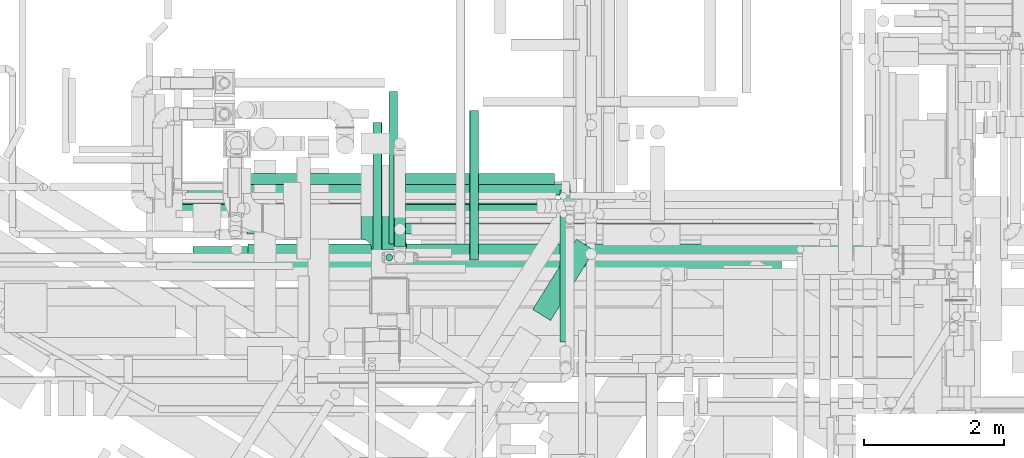
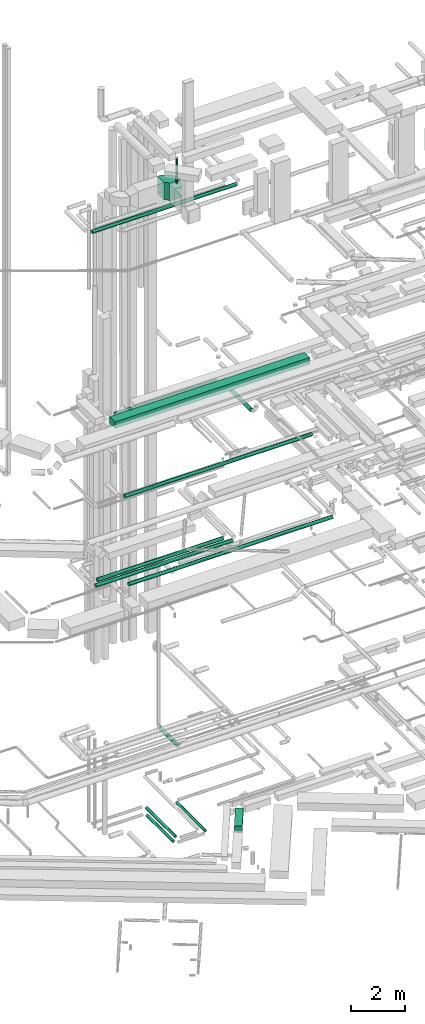
# One storey, part 27 of 337: 14 flow segments, 1 flow fitting.
"""IFC2X3 building model written with IfcOpenShell, lengths in millimetres."""

from ifc_helpers import new_model, entity, si_unit, converted_unit, derived_unit, direction, frame, frame_2d, origin, origin_2d_with_axis, place, context, subcontext, project, spatial, polyline, circle_curve, parameter, trimmed, segment, composite_curve, rectangle, circle, outline, extrude, source, transform, mapped, material, type_object, type_shapes, element, save


model = new_model("IFC2X3")

# Units and contexts
model_context = context("Model", 3, precision=0.01, world=origin(), true_north=direction((6.12303176911189e-17, 1.0)))
body_context = subcontext(model_context, "Body", "Model", "MODEL_VIEW")
ifc_project = project(units=[si_unit("LENGTHUNIT", "METRE", prefix="MILLI"), si_unit("AREAUNIT", "SQUARE_METRE"), si_unit("VOLUMEUNIT", "CUBIC_METRE"), converted_unit("PLANEANGLEUNIT", "DEGREE", entity("IfcRatioMeasure", 0.0174532925199433), si_unit("PLANEANGLEUNIT", "RADIAN"), dimensions=[0, 0, 0, 0, 0, 0, 0]), si_unit("MASSUNIT", "GRAM", prefix="KILO"), derived_unit("MASSDENSITYUNIT", [(si_unit("MASSUNIT", "GRAM", prefix="KILO"), 1), (si_unit("LENGTHUNIT", "METRE"), -3)]), derived_unit("MOMENTOFINERTIAUNIT", [(si_unit("LENGTHUNIT", "METRE"), 4)]), si_unit("TIMEUNIT", "SECOND"), si_unit("FREQUENCYUNIT", "HERTZ"), si_unit("THERMODYNAMICTEMPERATUREUNIT", "DEGREE_CELSIUS"), derived_unit("THERMALTRANSMITTANCEUNIT", [(si_unit("MASSUNIT", "GRAM", prefix="KILO"), 1), (si_unit("THERMODYNAMICTEMPERATUREUNIT", "KELVIN"), -1), (si_unit("TIMEUNIT", "SECOND"), -3)]), derived_unit("VOLUMETRICFLOWRATEUNIT", [(si_unit("LENGTHUNIT", "METRE"), 3), (si_unit("TIMEUNIT", "SECOND"), -1)]), derived_unit("MASSFLOWRATEUNIT", [(si_unit("MASSUNIT", "GRAM", prefix="KILO"), 1), (si_unit("TIMEUNIT", "SECOND"), -1)]), derived_unit("ROTATIONALFREQUENCYUNIT", [(si_unit("TIMEUNIT", "SECOND"), -1)]), si_unit("ELECTRICCURRENTUNIT", "AMPERE"), si_unit("ELECTRICVOLTAGEUNIT", "VOLT"), si_unit("POWERUNIT", "WATT"), si_unit("FORCEUNIT", "NEWTON", prefix="KILO"), si_unit("ILLUMINANCEUNIT", "LUX"), si_unit("LUMINOUSFLUXUNIT", "LUMEN"), si_unit("LUMINOUSINTENSITYUNIT", "CANDELA"), derived_unit("USERDEFINED", [(si_unit("MASSUNIT", "GRAM", prefix="KILO"), -1), (si_unit("LENGTHUNIT", "METRE"), -2), (si_unit("TIMEUNIT", "SECOND"), 3), (si_unit("LUMINOUSFLUXUNIT", "LUMEN"), 1)]), derived_unit("LINEARVELOCITYUNIT", [(si_unit("LENGTHUNIT", "METRE"), 1), (si_unit("TIMEUNIT", "SECOND"), -1)]), si_unit("PRESSUREUNIT", "PASCAL"), derived_unit("USERDEFINED", [(si_unit("LENGTHUNIT", "METRE"), -2), (si_unit("MASSUNIT", "GRAM", prefix="KILO"), 1), (si_unit("TIMEUNIT", "SECOND"), -2)]), derived_unit("LINEARFORCEUNIT", [(si_unit("MASSUNIT", "GRAM", prefix="KILO"), 1), (si_unit("LENGTHUNIT", "METRE"), 1), (si_unit("TIMEUNIT", "SECOND"), -2), (si_unit("LENGTHUNIT", "METRE"), -1)]), derived_unit("PLANARFORCEUNIT", [(si_unit("MASSUNIT", "GRAM", prefix="KILO"), 1), (si_unit("LENGTHUNIT", "METRE"), 1), (si_unit("TIMEUNIT", "SECOND"), -2), (si_unit("LENGTHUNIT", "METRE"), -2)])], contexts=[model_context])

# Site, building, storey
site_placement = place(None, origin())
site = spatial("IfcSite", under=ifc_project, at=site_placement, CompositionType="ELEMENT")
building_placement = place(site_placement, origin())
building = spatial("IfcBuilding", under=site, at=building_placement, CompositionType="ELEMENT")
storey_placement = place(building_placement, origin())
storey = spatial("IfcBuildingStorey", under=building, at=storey_placement, CompositionType="ELEMENT", Elevation=0.0)

# Flow segments
duct_segment_type_1 = type_object("IfcDuctSegmentType", PredefinedType="NOTDEFINED")
flow_segment_1_placement = place(storey_placement, frame((12420.35, 11411.16, -750.0)))
element("IfcFlowSegment", 1, at=flow_segment_1_placement, inside=storey, type_object=duct_segment_type_1, context=body_context, shape_type="SweptSolid", body=[
    extrude(rectangle(XDim=1180.32053409491, YDim=300.0, at=origin_2d_with_axis()), frame((439.26, 580.27, 0.0), z_axis=(0.0, 0.0, 1.0), x_axis=(0.528543816030324, 0.84890602220511, 0.0)), (0.0, 0.0, 1.0), 300.0),
])
flow_segment_2_placement = place(storey_placement, frame((7574.85, 12067.41, 19050.0)))
element("IfcFlowSegment", 2, at=flow_segment_2_placement, inside=storey, type_object=duct_segment_type_1, context=body_context, shape_type="SweptSolid", body=[
    extrude(rectangle(XDim=8392.00000000011, YDim=400.0, at=origin_2d_with_axis()), frame((4196.0, 200.0, 0.0)), (0.0, 0.0, 1.0), 300.000000000001),
])
duct_segment_type_2 = type_object("IfcDuctSegmentType", PredefinedType="NOTDEFINED")
flow_segment_3_placement = place(storey_placement, frame((10367.09, 12500.75, -864.1)))
element("IfcFlowSegment", 3, at=flow_segment_3_placement, inside=storey, type_object=duct_segment_type_2, context=body_context, shape_type="SweptSolid", body=[
    extrude(circle(Radius=62.5, at=origin_2d_with_axis()), frame((64.1, 0.0, 64.1), z_axis=(0.0, 1.0, 0.0), x_axis=(-1.0, 0.0, 0.0)), (0.0, 0.0, 1.0), 2174.7135316636),
])
flow_segment_4_placement = place(storey_placement, frame((10142.02, 12275.59, -864.1)))
element("IfcFlowSegment", 4, at=flow_segment_4_placement, inside=storey, type_object=duct_segment_type_2, context=body_context, shape_type="SweptSolid", body=[
    extrude(circle(Radius=62.5, at=origin_2d_with_axis()), frame((64.1, 0.0, 64.1), z_axis=(0.0, 1.0, 0.0), x_axis=(-1.0, 0.0, 0.0)), (0.0, 0.0, 1.0), 1959.03722000001),
])
flow_segment_5_placement = place(storey_placement, frame((11518.99, 12275.59, -864.1)))
element("IfcFlowSegment", 5, at=flow_segment_5_placement, inside=storey, type_object=duct_segment_type_2, context=body_context, shape_type="SweptSolid", body=[
    extrude(circle(Radius=62.5, at=origin_2d_with_axis()), frame((64.1, 0.0, 64.1), z_axis=(0.0, 1.0, 0.0), x_axis=(1.0, 0.0, 0.0)), (0.0, 0.0, 1.0), 2129.03277392674),
])
flow_segment_6_placement = place(storey_placement, frame((8357.33, 12344.09, 11388.4)))
element("IfcFlowSegment", 6, at=flow_segment_6_placement, inside=storey, type_object=duct_segment_type_2, context=body_context, shape_type="SweptSolid", body=[
    extrude(circle(Radius=80.0, at=origin_2d_with_axis()), frame((0.0, 81.6, 81.6), z_axis=(1.0, 0.0, 0.0), x_axis=(0.0, 1.0, 0.0)), (0.0, 0.0, 1.0), 8780.0),
])
flow_segment_7_placement = place(storey_placement, frame((7253.56, 12905.05, 11368.4)))
element("IfcFlowSegment", 7, at=flow_segment_7_placement, inside=storey, type_object=duct_segment_type_2, context=body_context, shape_type="SweptSolid", body=[
    extrude(circle(Radius=80.0, at=origin_2d_with_axis()), frame((0.0, 81.6, 81.6), z_axis=(1.0, 0.0, 0.0), x_axis=(0.0, -1.0, 0.0)), (0.0, 0.0, 1.0), 5910.00000000001),
])
flow_segment_8_placement = place(storey_placement, frame((7493.56, 13198.67, 11368.4)))
element("IfcFlowSegment", 8, at=flow_segment_8_placement, inside=storey, type_object=duct_segment_type_2, context=body_context, shape_type="SweptSolid", body=[
    extrude(circle(Radius=80.0, at=origin_2d_with_axis()), frame((0.0, 81.6, 81.6), z_axis=(1.0, 0.0, 0.0), x_axis=(0.0, -1.0, 0.0)), (0.0, 0.0, 1.0), 5430.00000000002),
])
flow_segment_9_placement = place(storey_placement, frame((8347.33, 12644.09, 15218.4)))
element("IfcFlowSegment", 9, at=flow_segment_9_placement, inside=storey, type_object=duct_segment_type_2, context=body_context, shape_type="SweptSolid", body=[
    extrude(circle(Radius=80.0, at=origin_2d_with_axis()), frame((0.0, 81.6, 81.6), z_axis=(1.0, 0.0, 0.0), x_axis=(0.0, 1.0, 0.0)), (0.0, 0.0, 1.0), 8079.89506180345),
])
flow_segment_10_placement = place(storey_placement, frame((8349.69, 13348.75, 18528.4)))
element("IfcFlowSegment", 10, at=flow_segment_10_placement, inside=storey, type_object=duct_segment_type_2, context=body_context, shape_type="SweptSolid", body=[
    extrude(circle(Radius=80.0, at=origin_2d_with_axis()), frame((0.0, 81.6, 81.6), z_axis=(1.0, 0.0, 0.0), x_axis=(0.0, -1.0, 0.0)), (0.0, 0.0, 1.0), 4380.00000000001),
])
flow_segment_11_placement = place(storey_placement, frame((12808.1, 11108.08, 18528.4)))
element("IfcFlowSegment", 11, at=flow_segment_11_placement, inside=storey, type_object=duct_segment_type_2, context=body_context, shape_type="SweptSolid", body=[
    extrude(circle(Radius=80.0, at=origin_2d_with_axis()), frame((81.6, 0.0, 81.6), z_axis=(0.0, 1.0, 0.0), x_axis=(-1.0, 0.0, 0.0)), (0.0, 0.0, 1.0), 2162.26368744342),
])
flow_segment_12_placement = place(storey_placement, frame((7112.18, 12927.67, 27518.4)))
element("IfcFlowSegment", 12, at=flow_segment_12_placement, inside=storey, type_object=duct_segment_type_2, context=body_context, shape_type="SweptSolid", body=[
    extrude(circle(Radius=80.0, at=origin_2d_with_axis()), frame((0.0, 81.6, 81.6), z_axis=(1.0, 0.0, 0.0), x_axis=(0.0, -1.0, 0.0)), (0.0, 0.0, 1.0), 6240.00000000003),
])
flow_segment_13_placement = place(storey_placement, frame((10322.05, 12260.26, 29120.0)))
element("IfcFlowSegment", 13, at=flow_segment_13_placement, inside=storey, type_object=duct_segment_type_2, context=body_context, shape_type="SweptSolid", body=[
    extrude(circle(Radius=50.0, at=origin_2d_with_axis()), frame((51.6, 51.6, 0.0)), (0.0, 0.0, 1.0), 1129.99999999998),
])
flow_segment_14_placement = place(storey_placement, frame((10443.31, 12470.36, 3238.4)))
element("IfcFlowSegment", 14, at=flow_segment_14_placement, inside=storey, type_object=duct_segment_type_2, context=body_context, shape_type="SweptSolid", body=[
    extrude(circle(Radius=80.0, at=origin_2d_with_axis()), frame((81.6, 0.0, 81.6), z_axis=(0.0, 1.0, 0.0), x_axis=(-1.0, 0.0, 0.0)), (0.0, 0.0, 1.0), 1306.14344412801),
])

# Flow fitting
ifc_material = material()
duct_fitting_type = type_object("IfcDuctFittingType", PredefinedType="NOTDEFINED", material=ifc_material)
shared_shape = source(origin(), body_context, "Body", "SweptSolid", [
    extrude(outline(composite_curve([segment(polyline([(-450.0, -200.0), (50.0, -200.0)]), True, "CONTINUOUS"), segment(trimmed(circle_curve(frame_2d((200.0, -200.0), x_axis=(0.0, 1.0)), 150.0), [parameter(0.0)], [parameter(90.0000000000001)], True, "PARAMETER"), False, "CONTINUOUS"), segment(polyline([(200.0, -50.0), (200.0, 450.0)]), True, "CONTINUOUS"), segment(trimmed(circle_curve(frame_2d((200.0, -200.0), x_axis=(0.0, 1.0)), 650.0), [parameter(0.0)], [parameter(90.0000000000001)], True, "PARAMETER"), True, "CONTINUOUS")], self_intersect=False)), frame((-200.0, 200.0, -400.0), z_axis=(0.0, 0.0, 1.0), x_axis=(-1.0, 0.0, 0.0)), (0.0, 0.0, 1.0), 800.0),
])
type_shapes(duct_fitting_type, [shared_shape])
flow_fitting_placement = place(storey_placement, frame((10373.64, 12822.81, 28700.0), z_axis=(0.0, 0.0, 1.0), x_axis=(0.0, 1.0, 0.0)))
element("IfcFlowFitting", 15, at=flow_fitting_placement, inside=storey, type_object=duct_fitting_type, material=ifc_material, context=body_context, shape_type="MappedRepresentation", body=[
    mapped(shared_shape, transform((0.0, 0.0, 0.0), scale=1.0)),
])

save(model, "model.ifc")
